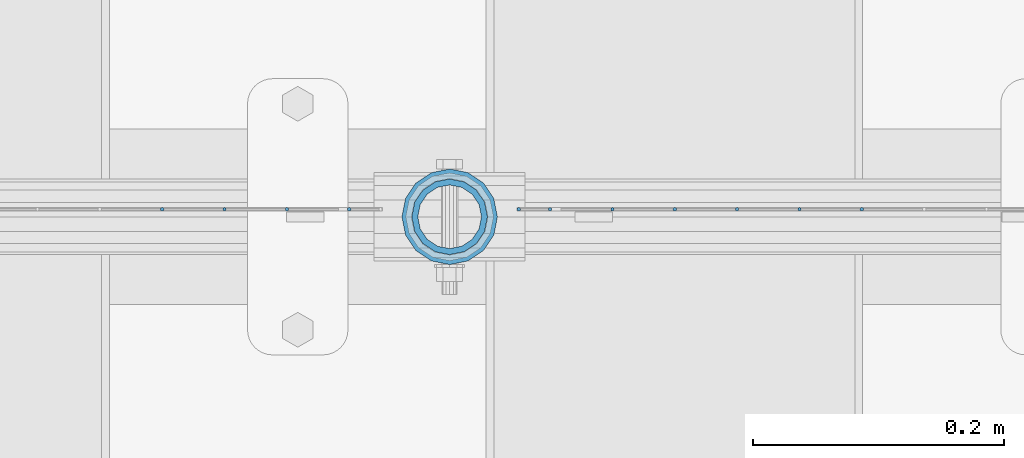
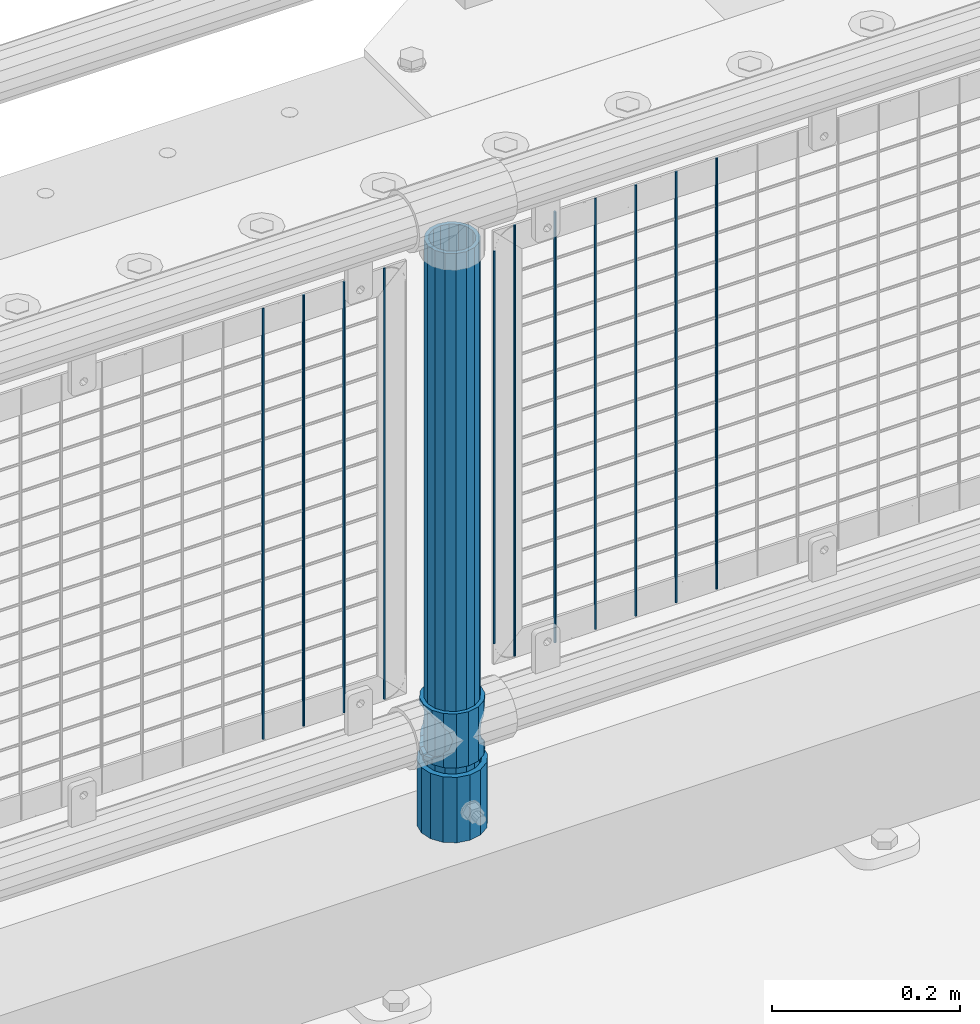
# One storey, part 81 of 257: 14 columns.
"""IFC2X3 building model written with IfcOpenShell, lengths in millimetres."""

from ifc_helpers import new_model, si_unit, frame, origin_with_axes, place, context, subcontext, project, spatial, faceted_brep, material, type_object, element, save


model = new_model("IFC2X3")

# Units and contexts
model_context = context("Model", 3, precision=1e-05, world=origin_with_axes())
body_context = subcontext(model_context, "Body", "Model", "MODEL_VIEW")
ifc_project = project(units=[si_unit("LENGTHUNIT", "METRE", prefix="MILLI"), si_unit("AREAUNIT", "SQUARE_METRE"), si_unit("VOLUMEUNIT", "CUBIC_METRE"), si_unit("MASSUNIT", "GRAM", prefix="KILO"), si_unit("TIMEUNIT", "SECOND"), si_unit("PLANEANGLEUNIT", "RADIAN"), si_unit("SOLIDANGLEUNIT", "STERADIAN"), si_unit("THERMODYNAMICTEMPERATUREUNIT", "DEGREE_CELSIUS"), si_unit("LUMINOUSINTENSITYUNIT", "LUMEN")], contexts=[model_context])

# Site, building, storey
site_placement = place(None, origin_with_axes())
site = spatial("IfcSite", under=ifc_project, at=site_placement, CompositionType="ELEMENT")
building_placement = place(site_placement, origin_with_axes())
building = spatial("IfcBuilding", under=site, at=building_placement, Name="Standard", CompositionType="ELEMENT")
storey_placement = place(building_placement, origin_with_axes())
storey = spatial("IfcBuildingStorey", under=building, at=storey_placement, Name="Undefined", CompositionType="ELEMENT", Elevation=0.0)

# Columns
ifc_material_1 = material()
column_type_1 = type_object("IfcColumnType", PredefinedType="NOTDEFINED")
column_1_placement = place(storey_placement, frame((51071.0, 10664.5, 168.02), z_axis=(0.0, 1.0, 0.0), x_axis=(0.0, 0.0, 1.0)))
element("IfcColumn", 1, at=column_1_placement, inside=storey, type_object=column_type_1, material=ifc_material_1, context=body_context, shape_type="Brep", body=[
    faceted_brep([(0.0, -31.75, 0.0), (0.0, -29.3331751572332, 12.1501989775916), (85.0, -29.3331751572332, 12.1501989775916), (85.0, -31.75, 0.0), (0.0, -22.4506403026753, 22.4506403026735), (85.0, -22.4506403026753, 22.4506403026735), (0.0, -12.1501989775934, 29.3331751572332), (85.0, -12.1501989775934, 29.3331751572332), (0.0, 0.0, 31.75), (85.0, 0.0, 31.75), (0.0, 12.1501989775934, 29.3331751572332), (85.0, 12.1501989775934, 29.3331751572332), (0.0, 22.4506403026753, 22.4506403026735), (85.0, 22.4506403026753, 22.4506403026735), (0.0, 29.3331751572332, 12.1501989775916), (85.0, 29.3331751572332, 12.1501989775916), (0.0, 31.75, 0.0), (85.0, 31.75, 0.0), (0.0, 29.3331751572332, -12.1501989775916), (85.0, 29.3331751572332, -12.1501989775916), (0.0, 22.4506403026753, -22.4506403026735), (85.0, 22.4506403026753, -22.4506403026735), (0.0, 12.1501989775934, -29.3331751572332), (85.0, 12.1501989775934, -29.3331751572332), (0.0, 0.0, -31.75), (85.0, 0.0, -31.75), (0.0, -12.1501989775934, -29.3331751572332), (85.0, -12.1501989775934, -29.3331751572332), (0.0, -22.4506403026753, -22.4506403026735), (85.0, -22.4506403026753, -22.4506403026735), (0.0, -29.3331751572332, -12.1501989775916), (85.0, -29.3331751572332, -12.1501989775916), (0.0, -38.0500000000029, 0.0), (0.0, -35.1536162120537, -14.561104601491), (85.0, -35.1536162120537, -14.561104601491), (85.0, -38.0500000000029, 0.0), (0.0, -26.9054130241493, -26.9054130241475), (85.0, -26.9054130241493, -26.9054130241475), (0.0, -14.5611046014892, -35.1536162120537), (85.0, -14.5611046014892, -35.1536162120537), (0.0, 0.0, -38.0499999999993), (85.0, 0.0, -38.0499999999993), (0.0, 14.5611046014892, -35.1536162120537), (85.0, 14.5611046014892, -35.1536162120537), (0.0, 26.9054130241493, -26.9054130241475), (85.0, 26.9054130241493, -26.9054130241475), (0.0, 35.1536162120537, -14.561104601491), (85.0, 35.1536162120537, -14.561104601491), (0.0, 38.0500000000029, 0.0), (85.0, 38.0500000000029, 0.0), (0.0, 35.1536162120537, 14.561104601491), (85.0, 35.1536162120537, 14.561104601491), (0.0, 26.9054130241493, 26.9054130241475), (85.0, 26.9054130241493, 26.9054130241475), (0.0, 14.5611046014892, 35.1536162120537), (85.0, 14.5611046014892, 35.1536162120537), (0.0, 0.0, 38.0499999999993), (85.0, 0.0, 38.0499999999993), (0.0, -14.5611046014892, 35.1536162120537), (85.0, -14.5611046014892, 35.1536162120537), (0.0, -26.9054130241493, 26.9054130241475), (85.0, -26.9054130241493, 26.9054130241475), (0.0, -35.1536162120537, 14.561104601491), (85.0, -35.1536162120537, 14.561104601491)], [[[0, 1, 2, 3]], [[1, 4, 5, 2]], [[4, 6, 7, 5]], [[6, 8, 9, 7]], [[8, 10, 11, 9]], [[10, 12, 13, 11]], [[12, 14, 15, 13]], [[14, 16, 17, 15]], [[16, 18, 19, 17]], [[18, 20, 21, 19]], [[20, 22, 23, 21]], [[22, 24, 25, 23]], [[24, 26, 27, 25]], [[26, 28, 29, 27]], [[28, 30, 31, 29]], [[30, 0, 3, 31]], [[32, 33, 34, 35]], [[33, 36, 37, 34]], [[36, 38, 39, 37]], [[38, 40, 41, 39]], [[40, 42, 43, 41]], [[42, 44, 45, 43]], [[44, 46, 47, 45]], [[46, 48, 49, 47]], [[48, 50, 51, 49]], [[50, 52, 53, 51]], [[52, 54, 55, 53]], [[54, 56, 57, 55]], [[56, 58, 59, 57]], [[58, 60, 61, 59]], [[60, 62, 63, 61]], [[62, 32, 35, 63]], [[37, 39, 41, 43, 45, 47, 49, 51, 53, 55, 57, 59, 61, 63, 35, 34], [5, 7, 9, 11, 13, 15, 17, 19, 21, 23, 25, 27, 29, 31, 3, 2]], [[62, 60, 58, 56, 54, 52, 50, 48, 46, 44, 42, 40, 38, 36, 33, 32], [30, 28, 26, 24, 22, 20, 18, 16, 14, 12, 10, 8, 6, 4, 1, 0]]]),
])
ifc_material_2 = material(Name="Misc_Undefined")
column_type_2 = type_object("IfcColumnType", PredefinedType="NOTDEFINED")
column_2_placement = place(storey_placement, frame((51071.0, 10664.5, 263.02), z_axis=(-1.0, 0.0, 0.0), x_axis=(0.0, 0.0, 1.0)))
element("IfcColumn", 2, at=column_2_placement, inside=storey, type_object=column_type_2, material=ifc_material_2, context=body_context, shape_type="Brep", body=[
    faceted_brep([(63.1897438117172, 11.6144421722802, -32.8397438117245), (63.1897438117172, 11.6144421722802, -28.0397438117143), (56.6106908090114, 21.4606908090118, -21.4606908090136), (56.6106908090114, 21.4606908090118, -27.1226768591077), (61.9623795176756, 13.4513226476338, -32.4743655677739), (46.7644421722801, 28.0397438117179, -11.6144421722784), (46.7644421722801, 28.0397438117179, -20.0882031229921), (51.5310424080039, 24.8548033587067, -24.8548033587067), (35.1500000000015, 30.35, 0.0), (35.1499999999996, 30.3500000000004, -16.6306603983758), (23.5355578277192, 28.0397438117179, -11.6144421722784), (23.5355578277192, 28.0397438117179, -20.0882031229921), (18.7689575919954, 24.8548033587067, -24.8548033587067), (13.6893091909879, 21.4606908090118, -21.4606908090136), (13.6893091909879, 21.4606908090118, -27.1226768591077), (8.3376204823237, 13.4513226476338, -32.4743655677739), (7.11025618828211, 11.6144421722802, -28.0397438117143), (7.11025618828211, 11.6144421722802, -32.8397438117245), (4.79999999999961, 0.0, -30.3499999999985), (4.79999999999961, 0.0, -35.1500000000015), (7.11025618828205, -11.6144421722802, -28.0397438117143), (7.11025618828205, -11.6144421722802, -32.8397438117245), (13.6893091909879, -21.4606908090118, -21.4606908090136), (13.6893091909879, -21.4606908090118, -27.1226768591077), (8.33762048232484, -13.4513226476338, -32.4743655677739), (23.5355578277191, -28.0397438117179, -11.6144421722784), (23.5355578277191, -28.0397438117179, -20.0882031229849), (18.7689575919987, -24.8548033587067, -24.8548033587067), (35.1500000000015, -30.35, 0.0), (35.1499999999996, -30.3500000000004, -16.6306603983685), (46.7644421722801, -28.0397438117179, -11.6144421722784), (46.7644421722801, -28.0397438117179, -20.0882031229849), (51.5310424080038, -24.8548033587067, -24.8548033587067), (56.6106908090114, -21.4606908090118, -21.4606908090136), (56.6106908090114, -21.4606908090118, -27.1226768591077), (61.9623795176756, -13.4513226476338, -32.4743655677739), (63.1897438117172, -11.6144421722802, -28.0397438117143), (63.1897438117172, -11.6144421722802, -32.8397438117245), (65.4999999999997, 0.0, -30.3499999999985), (65.4999999999997, 0.0, -35.1500000000015), (0.0, -28.0397438117179, -11.6144421722784), (0.0, -30.3500000000004, 0.0), (0.0, -21.4606908090118, -21.4606908090136), (0.0, -11.6144421722802, -28.0397438117143), (0.0, 0.0, -30.3499999999985), (0.0, 11.6144421722802, -28.0397438117143), (0.0, 21.4606908090118, -21.4606908090136), (0.0, 28.0397438117179, -11.6144421722784), (0.0, 30.3500000000004, 0.0), (0.0, 28.0397438117179, 11.6144421722784), (23.5355578277192, 28.0397438117179, 11.6144421722784), (0.0, 21.4606908090118, 21.4606908090136), (13.6893091909879, 21.4606908090118, 21.4606908090136), (0.0, 11.6144421722802, 28.0397438117143), (7.11025618828211, 11.6144421722802, 28.0397438117143), (0.0, 0.0, 30.3499999999985), (4.79999999999961, 0.0, 30.3499999999985), (0.0, -11.6144421722802, 28.0397438117143), (7.11025618828205, -11.6144421722802, 28.0397438117143), (0.0, -21.4606908090118, 21.4606908090136), (13.6893091909879, -21.4606908090118, 21.4606908090136), (0.0, -28.0397438117179, 11.6144421722784), (23.5355578277191, -28.0397438117179, 11.6144421722784), (0.0, -32.4743655677721, 13.4513226476338), (0.0, -35.1499999999996, 0.0), (70.2999999999993, -35.1499999999996, 0.0), (70.2999999999993, -32.4743655677721, 13.4513226476338), (0.0, 13.4513226476338, -32.4743655677739), (0.0, 24.8548033587067, -24.8548033587067), (0.0, 0.0, -35.1499999999996), (0.0, -13.4513226476338, -32.4743655677739), (0.0, -24.8548033587067, -24.8548033587067), (0.0, -24.8548033587067, 24.8548033587067), (0.0, -13.4513226476338, 32.4743655677739), (0.0, 0.0, 35.1499999999996), (0.0, 13.4513226476338, 32.4743655677739), (0.0, 24.8548033587067, 24.8548033587067), (0.0, 32.4743655677721, 13.4513226476338), (0.0, 35.1499999999996, 0.0), (0.0, 32.4743655677721, -13.4513226476338), (0.0, -32.4743655677721, -13.4513226476338), (70.2999999999993, 32.4743655677721, 13.4513226476338), (70.2999999999993, 35.1499999999996, 0.0), (70.2999999999993, 32.4743655677721, -13.4513226476338), (70.2999999999993, 24.8548033587067, -24.8548033587067), (70.2999999999993, 13.4513226476338, -32.4743655677739), (70.2999999999993, 0.0, -35.1500000000015), (70.2999999999993, -13.4513226476338, -32.4743655677739), (70.2999999999993, -24.8548033587067, -24.8548033587067), (70.2999999999993, -32.4743655677721, -13.4513226476338), (70.2999999999993, 28.0397438117179, 11.6144421722784), (70.2999999999993, 21.4606908090118, 21.4606908090136), (56.6106908090114, 21.4606908090118, 21.4606908090136), (46.7644421722801, 28.0397438117179, 11.6144421722784), (70.2999999999993, 11.6144421722802, 28.0397438117143), (63.1897438117172, 11.6144421722802, 28.0397438117143), (70.2999999999993, 0.0, 30.3499999999985), (65.4999999999997, 0.0, 30.3499999999985), (70.2999999999993, -11.6144421722802, 28.0397438117143), (63.1897438117172, -11.6144421722802, 28.0397438117143), (70.2999999999993, -21.4606908090118, 21.4606908090136), (56.6106908090114, -21.4606908090118, 21.4606908090136), (70.2999999999993, -28.0397438117179, 11.6144421722784), (46.7644421722801, -28.0397438117179, 11.6144421722784), (70.2999999999993, -11.6144421722802, -28.0397438117143), (70.2999999999993, 0.0, -30.3499999999985), (70.2999999999993, -21.4606908090118, -21.4606908090136), (70.2999999999993, -28.0397438117179, -11.6144421722784), (70.2999999999993, -30.3500000000004, 0.0), (70.2999999999993, 24.8548033587067, 24.8548033587067), (70.2999999999993, 13.4513226476338, 32.4743655677739), (70.2999999999993, 0.0, 35.1500000000015), (70.2999999999993, -13.4513226476338, 32.4743655677739), (70.2999999999993, -24.8548033587067, 24.8548033587067), (70.2999999999993, 30.3500000000004, 0.0), (70.2999999999993, 28.0397438117179, -11.6144421722784), (70.2999999999993, 21.4606908090118, -21.4606908090136), (70.2999999999993, 11.6144421722802, -28.0397438117143), (61.9623795176756, 13.4513226476338, 32.4743655677739), (51.5310424080039, 24.8548033587067, 24.8548033587067), (56.6106908090114, 21.4606908090118, 27.1226768591077), (65.4999999999997, 0.0, 35.1500000000015), (63.1897438117172, 11.6144421722802, 32.8397438117172), (63.1897438117172, -11.6144421722802, 32.8397438117172), (61.9623795176756, -13.4513226476338, 32.4743655677739), (56.6106908090114, -21.4606908090118, 27.1226768591077), (51.5310424080071, -24.8548033587067, 24.8548033587067), (18.7689575919987, -24.8548033587067, 24.8548033587067), (46.7644421722801, -28.0397438117179, 20.0882031229703), (35.1499999999996, -30.3500000000004, 16.6306603983539), (23.5355578277191, -28.0397438117179, 20.0882031229703), (8.3376204823237, -13.4513226476338, 32.4743655677739), (13.6893091909879, -21.4606908090118, 27.1226768591077), (4.79999999999961, 0.0, 35.1500000000015), (7.11025618828205, -11.6144421722802, 32.8397438117172), (7.11025618828211, 11.6144421722802, 32.8397438117172), (8.3376204823237, 13.4513226476338, 32.4743655677739), (13.6893091909879, 21.4606908090118, 27.1226768591077), (18.7689575919954, 24.8548033587067, 24.8548033587067), (23.5355578277192, 28.0397438117179, 20.0882031229849), (35.1499999999996, 30.3500000000004, 16.6306603983685), (46.7644421722801, 28.0397438117179, 20.0882031229849)], [[[0, 1, 2, 3, 4]], [[3, 2, 5, 6, 7]], [[6, 5, 8, 9]], [[9, 8, 10, 11]], [[12, 11, 10, 13, 14]], [[15, 14, 13, 16, 17]], [[17, 16, 18, 19]], [[19, 18, 20, 21]], [[21, 20, 22, 23, 24]], [[23, 22, 25, 26, 27]], [[26, 25, 28, 29]], [[29, 28, 30, 31]], [[32, 31, 30, 33, 34]], [[35, 34, 33, 36, 37]], [[37, 36, 38, 39]], [[39, 38, 1, 0]], [[40, 41, 28, 25]], [[42, 40, 25, 22]], [[43, 42, 22, 20]], [[44, 43, 20, 18]], [[45, 44, 18, 16]], [[46, 45, 16, 13]], [[47, 46, 13, 10]], [[48, 47, 10, 8]], [[49, 48, 8, 50]], [[51, 49, 50, 52]], [[53, 51, 52, 54]], [[55, 53, 54, 56]], [[57, 55, 56, 58]], [[59, 57, 58, 60]], [[61, 59, 60, 62]], [[41, 61, 62, 28]], [[63, 64, 65, 66]], [[67, 68, 12, 14, 15]], [[69, 67, 15, 17, 19]], [[24, 70, 69, 19, 21]], [[27, 71, 70, 24, 23]], [[63, 72, 73, 74, 75, 76, 77, 78, 79, 68, 67, 69, 70, 71, 80, 64], [40, 42, 43, 44, 45, 46, 47, 48, 49, 51, 53, 55, 57, 59, 61, 41]], [[78, 77, 81, 82]], [[79, 78, 82, 83]], [[9, 11, 12, 68, 79, 83, 84, 7, 6]], [[7, 84, 85, 4, 3]], [[4, 85, 86, 39, 0]], [[87, 88, 32, 34, 35]], [[86, 87, 35, 37, 39]], [[88, 89, 80, 71, 27, 26, 29, 31, 32]], [[64, 80, 89, 65]], [[90, 91, 92, 93]], [[91, 94, 95, 92]], [[94, 96, 97, 95]], [[96, 98, 99, 97]], [[98, 100, 101, 99]], [[100, 102, 103, 101]], [[104, 105, 38, 36]], [[106, 104, 36, 33]], [[107, 106, 33, 30]], [[108, 107, 30, 28]], [[102, 108, 28, 103]], [[88, 87, 86, 85, 84, 83, 82, 81, 109, 110, 111, 112, 113, 66, 65, 89], [100, 98, 96, 94, 91, 90, 114, 115, 116, 117, 105, 104, 106, 107, 108, 102]], [[118, 110, 109, 119, 120]], [[121, 111, 110, 118, 122]], [[112, 111, 121, 123, 124]], [[113, 112, 124, 125, 126]], [[127, 72, 63, 66, 113, 126, 128, 129, 130]], [[131, 73, 72, 127, 132]], [[133, 74, 73, 131, 134]], [[75, 74, 133, 135, 136]], [[76, 75, 136, 137, 138]], [[119, 109, 81, 77, 76, 138, 139, 140, 141]], [[92, 120, 119, 141, 93]], [[95, 122, 118, 120, 92]], [[97, 121, 122, 95]], [[99, 123, 121, 97]], [[101, 125, 124, 123, 99]], [[103, 128, 126, 125, 101]], [[28, 129, 128, 103]], [[62, 130, 129, 28]], [[60, 132, 127, 130, 62]], [[58, 134, 131, 132, 60]], [[56, 133, 134, 58]], [[54, 135, 133, 56]], [[52, 137, 136, 135, 54]], [[50, 139, 138, 137, 52]], [[8, 140, 139, 50]], [[93, 141, 140, 8]], [[114, 90, 93, 8]], [[115, 114, 8, 5]], [[116, 115, 5, 2]], [[117, 116, 2, 1]], [[105, 117, 1, 38]]]),
])
column_type_3 = type_object("IfcColumnType", PredefinedType="NOTDEFINED")
column_3_placement = place(storey_placement, frame((51071.0, 10664.5, 168.02), z_axis=(-1.0, 0.0, 0.0), x_axis=(0.0, 0.0, 1.0)))
element("IfcColumn", 3, at=column_3_placement, inside=storey, type_object=column_type_3, material=ifc_material_1, context=body_context, shape_type="Brep", body=[
    faceted_brep([(0.0, -25.3500000000004, 0.0), (0.0, -23.4203461491616, 9.70102501045767), (760.0, -23.4203461491616, 9.70102501045767), (760.0, -25.3500000000004, 0.0), (0.0, -17.9251569030785, 17.9251569030821), (760.0, -17.9251569030785, 17.9251569030821), (0.0, -9.70102501045585, 23.4203461491634), (760.0, -9.70102501045585, 23.4203461491634), (0.0, 0.0, 25.3499999999985), (760.0, 0.0, 25.3499999999985), (0.0, 9.70102501045585, 23.4203461491634), (760.0, 9.70102501045585, 23.4203461491634), (0.0, 17.9251569030785, 17.9251569030821), (760.0, 17.9251569030785, 17.9251569030821), (0.0, 23.4203461491616, 9.70102501045767), (760.0, 23.4203461491616, 9.70102501045767), (0.0, 25.3500000000004, 0.0), (760.0, 25.3500000000004, 0.0), (0.0, 23.4203461491616, -9.70102501045767), (760.0, 23.4203461491616, -9.70102501045767), (0.0, 17.9251569030785, -17.9251569030821), (760.0, 17.9251569030785, -17.9251569030821), (0.0, 9.70102501045585, -23.4203461491634), (760.0, 9.70102501045585, -23.4203461491634), (0.0, 0.0, -25.3499999999985), (760.0, 0.0, -25.3499999999985), (0.0, -9.70102501045585, -23.4203461491634), (760.0, -9.70102501045585, -23.4203461491634), (0.0, -17.9251569030785, -17.9251569030821), (760.0, -17.9251569030785, -17.9251569030821), (0.0, -23.4203461491616, -9.70102501045767), (760.0, -23.4203461491616, -9.70102501045767), (0.0, -30.1499999999996, 0.0), (0.0, -27.8549679052157, -11.5379054858058), (760.0, -27.8549679052157, -11.5379054858058), (760.0, -30.1499999999996, 0.0), (0.0, -21.3192694527752, -21.3192694527752), (760.0, -21.3192694527752, -21.3192694527752), (0.0, -11.5379054858076, -27.8549679052157), (760.0, -11.5379054858076, -27.8549679052157), (0.0, 0.0, -30.1500000000015), (760.0, 0.0, -30.1500000000015), (0.0, 11.5379054858076, -27.8549679052157), (760.0, 11.5379054858076, -27.8549679052157), (0.0, 21.3192694527752, -21.3192694527752), (760.0, 21.3192694527752, -21.3192694527752), (0.0, 27.8549679052157, -11.5379054858058), (760.0, 27.8549679052157, -11.5379054858058), (0.0, 30.1499999999996, 0.0), (760.0, 30.1499999999996, 0.0), (0.0, 27.8549679052157, 11.5379054858058), (760.0, 27.8549679052157, 11.5379054858058), (0.0, 21.3192694527752, 21.3192694527752), (760.0, 21.3192694527752, 21.3192694527752), (0.0, 11.5379054858076, 27.8549679052157), (760.0, 11.5379054858076, 27.8549679052157), (0.0, 0.0, 30.1500000000015), (760.0, 0.0, 30.1500000000015), (0.0, -11.5379054858076, 27.8549679052157), (760.0, -11.5379054858076, 27.8549679052157), (0.0, -21.3192694527752, 21.3192694527752), (760.0, -21.3192694527752, 21.3192694527752), (0.0, -27.8549679052157, 11.5379054858058), (760.0, -27.8549679052157, 11.5379054858058)], [[[0, 1, 2, 3]], [[1, 4, 5, 2]], [[4, 6, 7, 5]], [[6, 8, 9, 7]], [[8, 10, 11, 9]], [[10, 12, 13, 11]], [[12, 14, 15, 13]], [[14, 16, 17, 15]], [[16, 18, 19, 17]], [[18, 20, 21, 19]], [[20, 22, 23, 21]], [[22, 24, 25, 23]], [[24, 26, 27, 25]], [[26, 28, 29, 27]], [[28, 30, 31, 29]], [[30, 0, 3, 31]], [[32, 33, 34, 35]], [[33, 36, 37, 34]], [[36, 38, 39, 37]], [[38, 40, 41, 39]], [[40, 42, 43, 41]], [[42, 44, 45, 43]], [[44, 46, 47, 45]], [[46, 48, 49, 47]], [[48, 50, 51, 49]], [[50, 52, 53, 51]], [[52, 54, 55, 53]], [[54, 56, 57, 55]], [[56, 58, 59, 57]], [[58, 60, 61, 59]], [[60, 62, 63, 61]], [[62, 32, 35, 63]], [[37, 39, 41, 43, 45, 47, 49, 51, 53, 55, 57, 59, 61, 63, 35, 34], [5, 7, 9, 11, 13, 15, 17, 19, 21, 23, 25, 27, 29, 31, 3, 2]], [[62, 60, 58, 56, 54, 52, 50, 48, 46, 44, 42, 40, 38, 36, 33, 32], [30, 28, 26, 24, 22, 20, 18, 16, 14, 12, 10, 8, 6, 4, 1, 0]]]),
])
column_type_4 = type_object("IfcColumnType", Name="D3", PredefinedType="NOTDEFINED")
for number, where, z_axis, x_axis in (
    (4, (51399.275, 10670.5, 353.020000000003), (-1.0, 0.0, 0.0), (0.0, 0.0, 1.0)),
    (5, (51349.62, 10670.5, 353.020000000003), (-1.0, 0.0, 0.0), (0.0, 0.0, 1.0)),
    (6, (51299.965, 10670.5, 353.020000000003), (-1.0, 0.0, 0.0), (0.0, 0.0, 1.0)),
    (7, (51250.3103448276, 10670.5, 353.020000000003), (-1.0, 0.0, 0.0), (0.0, 0.0, 1.0)),
    (8, (51200.6551724138, 10670.5, 353.020000000003), (-0.999999999962839, 0.0, 8.62099999968473e-06), (8.62099999949798e-06, 0.0, 0.999999999962839)),
):
    element("IfcColumn", number, at=place(storey_placement, frame(where, z_axis=z_axis, x_axis=x_axis)), inside=storey, type_object=column_type_4, material=ifc_material_2, ObjectType="D3", context=body_context, shape_type="Brep", body=[
        faceted_brep([(0.0, -1.5, -5.6843418860808e-14), (0.0, -0.750000000001819, -1.29903810567669), (560.0, -0.75, -1.29903810567339), (560.0, -1.5, 0.0), (7.27595761418343e-12, 0.749999999998181, -1.29903810567669), (560.0, 0.75, -1.29903810567339), (0.0, 1.5, -5.6843418860808e-14), (560.0, 1.5, 0.0), (7.27595761418343e-12, 0.749999999998181, 1.29903810567669), (560.0, 0.75, 1.29903810567339), (0.0, -0.750000000001819, 1.29903810567669), (560.0, -0.75, 1.29903810567339)], [[[0, 1, 2, 3]], [[1, 4, 5, 2]], [[4, 6, 7, 5]], [[6, 8, 9, 7]], [[8, 10, 11, 9]], [[10, 0, 3, 11]], [[5, 7, 9, 11, 3, 2]], [[10, 8, 6, 4, 1, 0]]]),
    ])
column_4_placement = place(storey_placement, frame((51126.0, 10670.5, 378.020000000003), z_axis=(-1.0, 0.0, 0.0), x_axis=(0.0, 0.0, 1.0)))
element("IfcColumn", 9, at=column_4_placement, inside=storey, type_object=column_type_4, material=ifc_material_2, ObjectType="D3", context=body_context, shape_type="Brep", body=[
    faceted_brep([(0.0, -1.5, -5.6843418860808e-14), (0.0, -0.750000000001819, -1.29903810567669), (510.0, -0.75, -1.29903810567339), (510.0, -1.5, 0.0), (7.27595761418343e-12, 0.749999999998181, -1.29903810567669), (510.0, 0.75, -1.29903810567339), (0.0, 1.5, -5.6843418860808e-14), (510.0, 1.5, 0.0), (7.27595761418343e-12, 0.749999999998181, 1.29903810567669), (510.0, 0.75, 1.29903810567339), (0.0, -0.750000000001819, 1.29903810567669), (510.0, -0.75, 1.29903810567339)], [[[0, 1, 2, 3]], [[1, 4, 5, 2]], [[4, 6, 7, 5]], [[6, 8, 9, 7]], [[8, 10, 11, 9]], [[10, 0, 3, 11]], [[5, 7, 9, 11, 3, 2]], [[10, 8, 6, 4, 1, 0]]]),
])
for number, where, z_axis, x_axis in (
    (10, (51151.0, 10670.5, 353.020000000003), (-1.0, 0.0, 0.0), (0.0, 0.0, 1.0)),
    (11, (50990.995, 10670.5, 353.020000000002), (-1.0, 0.0, 0.0), (0.0, 0.0, 1.0)),
    (12, (50941.34, 10670.5, 353.020000000002), (-1.0, 0.0, 0.0), (0.0, 0.0, 1.0)),
    (13, (50891.685, 10670.5, 353.020000000002), (-1.0, 0.0, 0.0), (0.0, 0.0, 1.0)),
    (14, (50842.03, 10670.5, 353.020000000002), (-1.0, 0.0, 0.0), (0.0, 0.0, 1.0)),
):
    element("IfcColumn", number, at=place(storey_placement, frame(where, z_axis=z_axis, x_axis=x_axis)), inside=storey, type_object=column_type_4, material=ifc_material_2, ObjectType="D3", context=body_context, shape_type="Brep", body=[
        faceted_brep([(0.0, -1.5, -5.6843418860808e-14), (0.0, -0.750000000001819, -1.29903810567669), (560.0, -0.75, -1.29903810567339), (560.0, -1.5, 0.0), (7.27595761418343e-12, 0.749999999998181, -1.29903810567669), (560.0, 0.75, -1.29903810567339), (0.0, 1.5, -5.6843418860808e-14), (560.0, 1.5, 0.0), (7.27595761418343e-12, 0.749999999998181, 1.29903810567669), (560.0, 0.75, 1.29903810567339), (0.0, -0.750000000001819, 1.29903810567669), (560.0, -0.75, 1.29903810567339)], [[[0, 1, 2, 3]], [[1, 4, 5, 2]], [[4, 6, 7, 5]], [[6, 8, 9, 7]], [[8, 10, 11, 9]], [[10, 0, 3, 11]], [[5, 7, 9, 11, 3, 2]], [[10, 8, 6, 4, 1, 0]]]),
    ])

save(model, "model.ifc")
